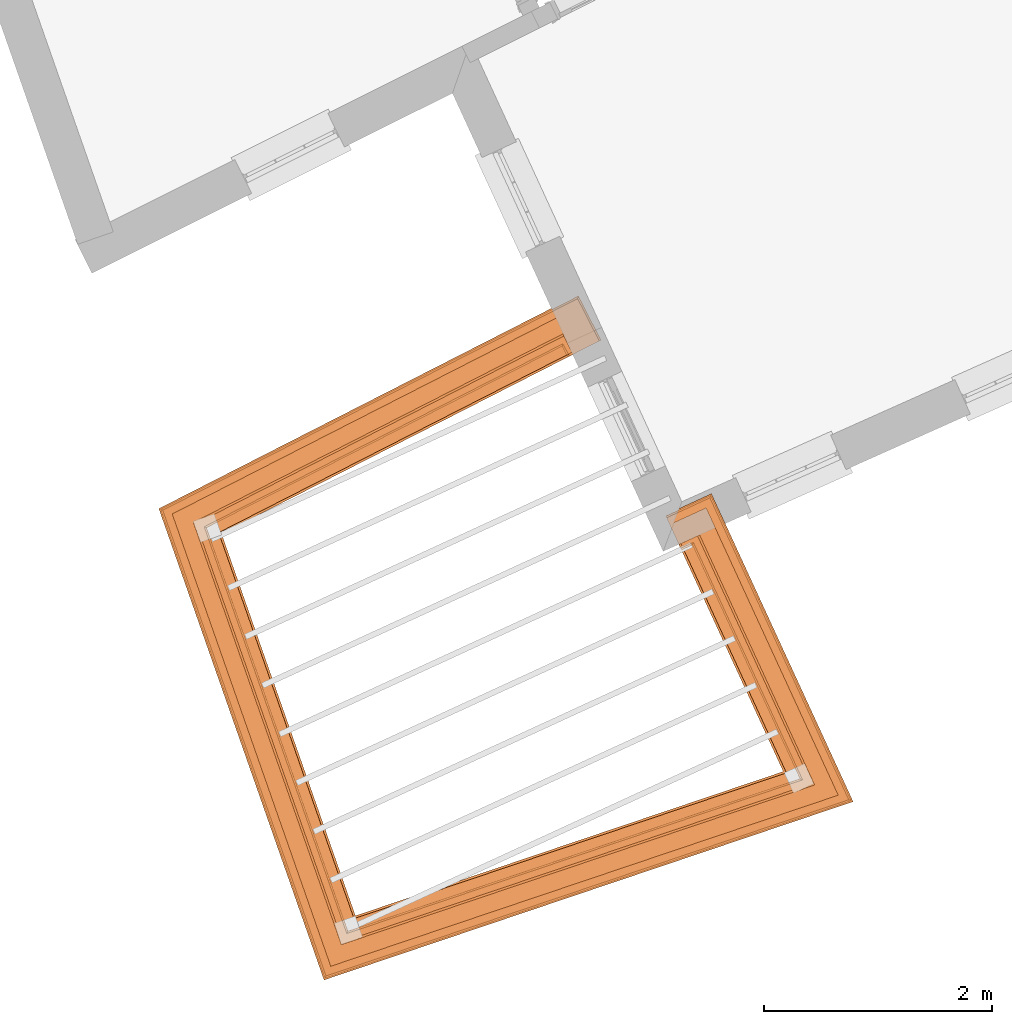
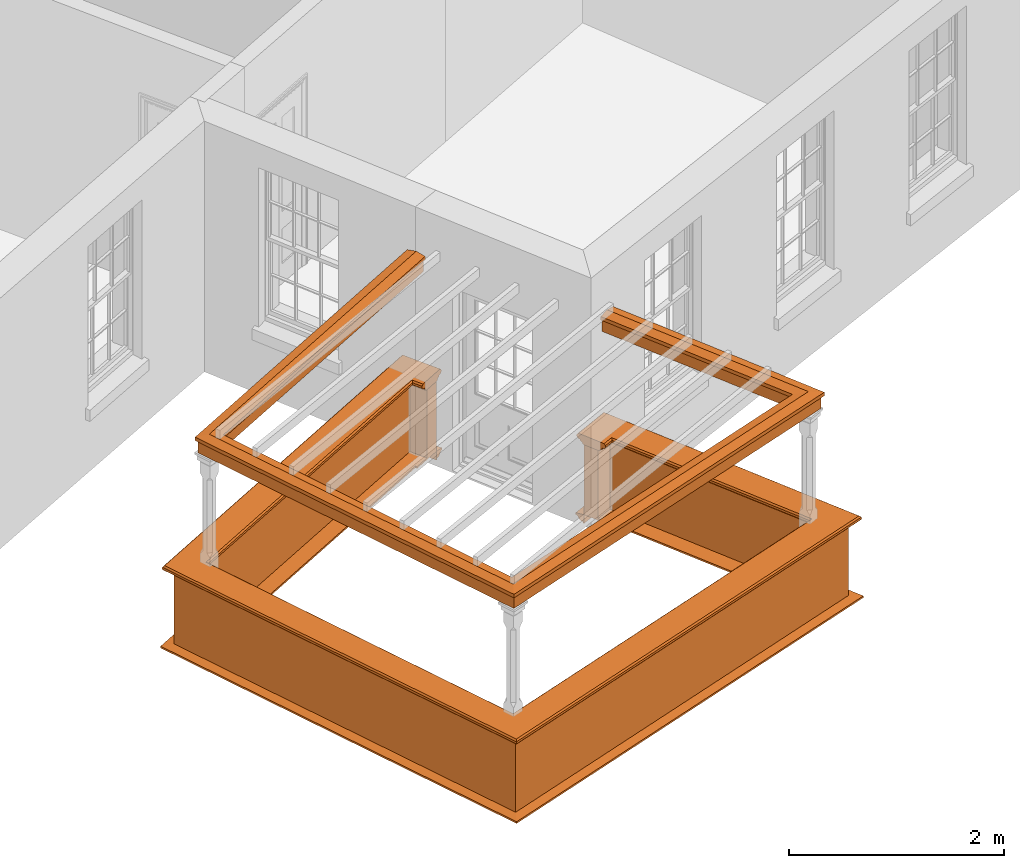
# One storey, part 8 of 9: 5 proxies.
"""IFC2X3 building model written with IfcOpenShell, lengths in metres."""

from ifc_helpers import new_model, entity, si_unit, frame, origin, place, context, subcontext, project, spatial, element, save


model = new_model("IFC2X3")

# Units and contexts
model_context = context("Model", 3, world=origin())
body_context = subcontext(model_context, "Body", "Model", "MODEL_VIEW")
ifc_project = project(units=[si_unit("PLANEANGLEUNIT", "RADIAN"), si_unit("MASSUNIT", "GRAM", prefix="KILO"), si_unit("FORCEUNIT", "NEWTON", prefix="KILO"), si_unit("LENGTHUNIT", "METRE")], contexts=[model_context])

# Site, building, storey
site_placement = place(None, origin())
site = spatial("IfcSite", under=ifc_project, at=site_placement, CompositionType="ELEMENT")
building_placement = place(None, origin())
building = spatial("IfcBuilding", under=site, at=building_placement, Name="Building plot-8", CompositionType="ELEMENT")
storey_placement = place(None, frame((0.0, 0.0, 3.45)))
storey = spatial("IfcBuildingStorey", under=building, at=storey_placement, Name="Floor 1", CompositionType="ELEMENT", Elevation=3.45)

# Proxies
proxy_1_placement = place(storey_placement, origin())
axis2_placement3_d_1 = entity("IfcAxis2Placement3D", entity("IfcCartesianPoint", [0.0, 0.0, 0.0]))
element("IfcBuildingElementProxy", 1, at=proxy_1_placement, inside=storey, Name="parapet", CompositionType="ELEMENT", context=body_context, shape_type="SweptSolid", held_by="IfcProductRepresentation", body=[
    entity("IfcSurfaceCurveSweptAreaSolid", entity("IfcArbitraryClosedProfileDef", "AREA", None, entity("IfcPolyline", [entity("IfcCartesianPoint", [0.0, 0.25]), entity("IfcCartesianPoint", [0.795, 0.25]), entity("IfcCartesianPoint", [0.795, 0.09]), entity("IfcCartesianPoint", [0.02, 0.09]), entity("IfcCartesianPoint", [0.02, -0.08]), entity("IfcCartesianPoint", [0.0, -0.08]), entity("IfcCartesianPoint", [0.0, 0.25])])), axis2_placement3_d_1, entity("IfcPolyline", [entity("IfcCartesianPoint", [24.6834048109124, 10.3974533198287]), entity("IfcCartesianPoint", [24.6379584445446, 10.4865298475112]), entity("IfcCartesianPoint", [21.5356027967568, 8.90372464572931]), entity("IfcCartesianPoint", [22.769491488676, 5.383345650084]), entity("IfcCartesianPoint", [26.7145237601106, 6.71336014777014]), entity("IfcCartesianPoint", [25.7787316342097, 8.74773209879351]), entity("IfcCartesianPoint", [25.6878822672872, 8.70594223722649])]), 0.0, 1.0, entity("IfcPlane", axis2_placement3_d_1)),
])
proxy_2_placement = place(storey_placement, origin())
axis2_placement3_d_2 = entity("IfcAxis2Placement3D", entity("IfcCartesianPoint", [0.0, 0.0, 0.0]))
element("IfcBuildingElementProxy", 2, at=proxy_2_placement, inside=storey, Name="parapet", CompositionType="ELEMENT", context=body_context, shape_type="SweptSolid", held_by="IfcProductRepresentation", body=[
    entity("IfcSurfaceCurveSweptAreaSolid", entity("IfcArbitraryClosedProfileDef", "AREA", None, entity("IfcPolyline", [entity("IfcCartesianPoint", [0.795, 0.265]), entity("IfcCartesianPoint", [0.807, 0.268]), entity("IfcCartesianPoint", [0.816, 0.274]), entity("IfcCartesianPoint", [0.822, 0.283]), entity("IfcCartesianPoint", [0.825, 0.295]), entity("IfcCartesianPoint", [0.84, 0.295]), entity("IfcCartesianPoint", [0.84, 0.305]), entity("IfcCartesianPoint", [0.842, 0.317]), entity("IfcCartesianPoint", [0.849, 0.326]), entity("IfcCartesianPoint", [0.858, 0.333]), entity("IfcCartesianPoint", [0.87, 0.335]), entity("IfcCartesianPoint", [0.882, 0.333]), entity("IfcCartesianPoint", [0.891, 0.326]), entity("IfcCartesianPoint", [0.898, 0.317]), entity("IfcCartesianPoint", [0.9, 0.305]), entity("IfcCartesianPoint", [0.9, 0.035]), entity("IfcCartesianPoint", [0.898, 0.023]), entity("IfcCartesianPoint", [0.891, 0.014]), entity("IfcCartesianPoint", [0.882, 0.007]), entity("IfcCartesianPoint", [0.87, 0.005]), entity("IfcCartesianPoint", [0.858, 0.007]), entity("IfcCartesianPoint", [0.849, 0.014]), entity("IfcCartesianPoint", [0.842, 0.023]), entity("IfcCartesianPoint", [0.84, 0.035]), entity("IfcCartesianPoint", [0.84, 0.045]), entity("IfcCartesianPoint", [0.825, 0.045]), entity("IfcCartesianPoint", [0.822, 0.057]), entity("IfcCartesianPoint", [0.816, 0.066]), entity("IfcCartesianPoint", [0.807, 0.072]), entity("IfcCartesianPoint", [0.795, 0.075]), entity("IfcCartesianPoint", [0.795, 0.265])])), axis2_placement3_d_2, entity("IfcPolyline", [entity("IfcCartesianPoint", [24.6834048109124, 10.3974533198287]), entity("IfcCartesianPoint", [24.6379584445446, 10.4865298475112]), entity("IfcCartesianPoint", [21.5356027967568, 8.90372464572931]), entity("IfcCartesianPoint", [22.769491488676, 5.383345650084]), entity("IfcCartesianPoint", [26.7145237601106, 6.71336014777014]), entity("IfcCartesianPoint", [25.7787316342097, 8.74773209879351]), entity("IfcCartesianPoint", [25.6878822672872, 8.70594223722649])]), 0.0, 1.0, entity("IfcPlane", axis2_placement3_d_2)),
])
proxy_3_placement = place(storey_placement, origin())
axis2_placement3_d_3 = entity("IfcAxis2Placement3D", entity("IfcCartesianPoint", [0.0, 0.0, 0.0]))
element("IfcBuildingElementProxy", 3, at=proxy_3_placement, inside=storey, Name="parapet", CompositionType="ELEMENT", context=body_context, shape_type="SweptSolid", held_by="IfcProductRepresentation", body=[
    entity("IfcSurfaceCurveSweptAreaSolid", entity("IfcArbitraryClosedProfileDef", "AREA", None, entity("IfcPolyline", [entity("IfcCartesianPoint", [-0.1, 0.25]), entity("IfcCartesianPoint", [-0.1, 0.265]), entity("IfcCartesianPoint", [-0.085, 0.265]), entity("IfcCartesianPoint", [-0.084, 0.278]), entity("IfcCartesianPoint", [-0.081, 0.289]), entity("IfcCartesianPoint", [-0.074, 0.301]), entity("IfcCartesianPoint", [-0.065, 0.309]), entity("IfcCartesianPoint", [-0.055, 0.315]), entity("IfcCartesianPoint", [-0.044, 0.324]), entity("IfcCartesianPoint", [-0.038, 0.334]), entity("IfcCartesianPoint", [-0.035, 0.345]), entity("IfcCartesianPoint", [-0.015, 0.345]), entity("IfcCartesianPoint", [0.0, 0.25]), entity("IfcCartesianPoint", [-0.1, 0.25])])), axis2_placement3_d_3, entity("IfcPolyline", [entity("IfcCartesianPoint", [24.6834048109124, 10.3974533198287]), entity("IfcCartesianPoint", [24.6379584445446, 10.4865298475112]), entity("IfcCartesianPoint", [21.5356027967568, 8.90372464572931]), entity("IfcCartesianPoint", [22.769491488676, 5.383345650084]), entity("IfcCartesianPoint", [26.7145237601106, 6.71336014777014]), entity("IfcCartesianPoint", [25.7787316342097, 8.74773209879351]), entity("IfcCartesianPoint", [25.6878822672872, 8.70594223722649])]), 0.0, 1.0, entity("IfcPlane", axis2_placement3_d_3)),
])
proxy_4_placement = place(storey_placement, frame((0.0, 0.0, 2.85)))
axis2_placement3_d_4 = entity("IfcAxis2Placement3D", entity("IfcCartesianPoint", [0.0, 0.0, 0.0]))
element("IfcBuildingElementProxy", 4, at=proxy_4_placement, inside=storey, Name="pergola beam", CompositionType="ELEMENT", context=body_context, shape_type="SweptSolid", held_by="IfcProductRepresentation", body=[
    entity("IfcSurfaceCurveSweptAreaSolid", entity("IfcArbitraryClosedProfileDef", "AREA", None, entity("IfcPolyline", [entity("IfcCartesianPoint", [-0.7, -0.08]), entity("IfcCartesianPoint", [-0.7, 0.08]), entity("IfcCartesianPoint", [-0.56, 0.08]), entity("IfcCartesianPoint", [-0.56, -0.08]), entity("IfcCartesianPoint", [-0.7, -0.08])])), axis2_placement3_d_4, entity("IfcPolyline", [entity("IfcCartesianPoint", [24.6914043611541, 10.5137976673319]), entity("IfcCartesianPoint", [21.5356027967568, 8.90372464572931]), entity("IfcCartesianPoint", [22.769491488676, 5.383345650084]), entity("IfcCartesianPoint", [26.7145237601106, 6.71336014777014]), entity("IfcCartesianPoint", [25.7536577172695, 8.80224171894698])]), 0.0, 1.0, entity("IfcPlane", axis2_placement3_d_4)),
])
proxy_5_placement = place(storey_placement, frame((0.0, 0.0, 2.85)))
axis2_placement3_d_5 = entity("IfcAxis2Placement3D", entity("IfcCartesianPoint", [0.0, 0.0, 0.0]))
element("IfcBuildingElementProxy", 5, at=proxy_5_placement, inside=storey, Name="pergola beam", CompositionType="ELEMENT", context=body_context, shape_type="SweptSolid", held_by="IfcProductRepresentation", body=[
    entity("IfcSurfaceCurveSweptAreaSolid", entity("IfcArbitraryClosedProfileDef", "AREA", None, entity("IfcPolyline", [entity("IfcCartesianPoint", [-0.5, 0.0]), entity("IfcCartesianPoint", [-0.52, -0.1]), entity("IfcCartesianPoint", [-0.56, -0.1]), entity("IfcCartesianPoint", [-0.56, 0.1]), entity("IfcCartesianPoint", [-0.52, 0.1]), entity("IfcCartesianPoint", [-0.5, 0.0])])), axis2_placement3_d_5, entity("IfcPolyline", [entity("IfcCartesianPoint", [24.6914043611541, 10.5137976673319]), entity("IfcCartesianPoint", [21.5356027967568, 8.90372464572931]), entity("IfcCartesianPoint", [22.769491488676, 5.383345650084]), entity("IfcCartesianPoint", [26.7145237601106, 6.71336014777014]), entity("IfcCartesianPoint", [25.7536577172695, 8.80224171894698])]), 0.0, 1.0, entity("IfcPlane", axis2_placement3_d_5)),
])

save(model, "model.ifc")
